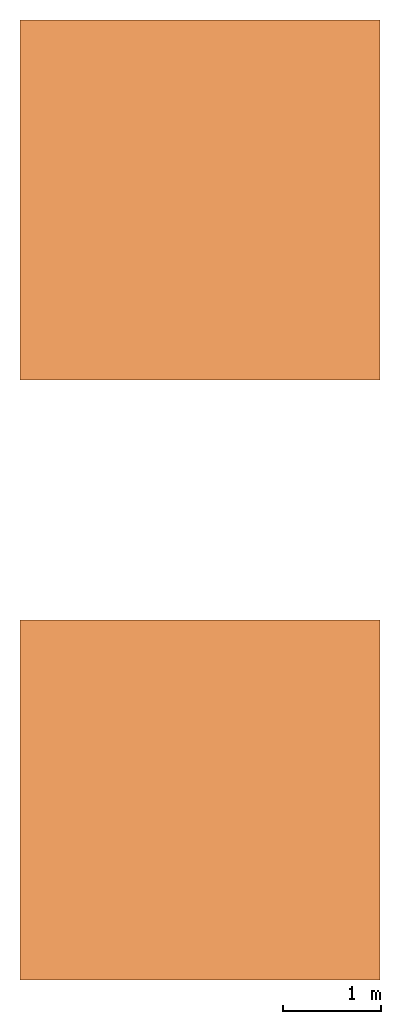
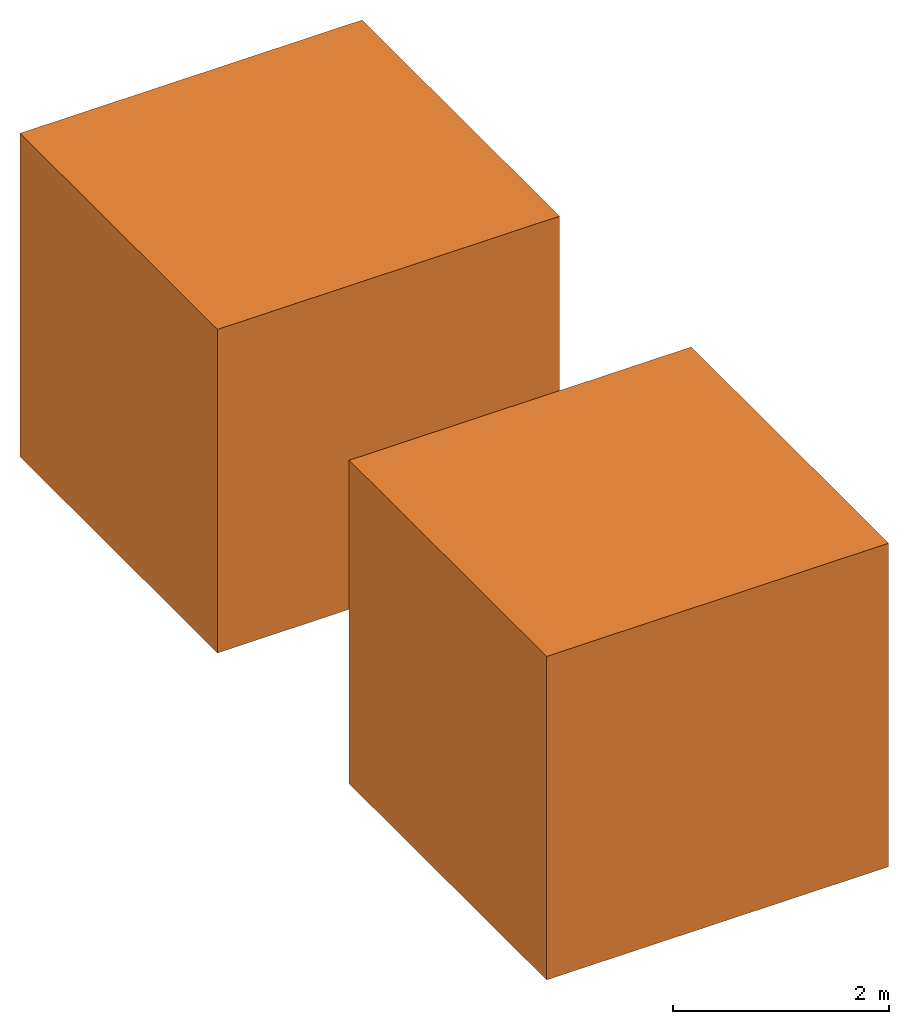
# One storey: 2 proxies.
"""IFC2X3 building model written with IfcOpenShell, lengths in feet."""

from ifc_helpers import new_model, entity, si_unit, converted_unit, frame, frame_2d, origin_with_axes, place, context, subcontext, project, spatial, faceted_brep, source, transform, mapped, material, type_object, type_shapes, element, save


model = new_model("IFC2X3")

# Units and contexts
model_context = context("Model", 3, precision=1e-05, world=origin_with_axes())
plan_context = context("Plan", 2, precision=1e-05, world=frame_2d((0.0, 0.0, 0.0), x_axis=(1.0, 0.0, 0.0)))
body_context = subcontext(model_context, "Body", "Model", "MODEL_VIEW")
ifc_project = project(units=[converted_unit("VOLUMEUNIT", "cubic foot", entity("IfcReal", 0.0283168467116885), si_unit("VOLUMEUNIT", "CUBIC_METRE"), dimensions=[3, 0, 0, 0, 0, 0, 0]), converted_unit("LENGTHUNIT", "foot", entity("IfcReal", 0.3048), si_unit("LENGTHUNIT", "METRE"), dimensions=[1, 0, 0, 0, 0, 0, 0]), converted_unit("AREAUNIT", "square foot", entity("IfcReal", 0.09290304), si_unit("AREAUNIT", "SQUARE_METRE"), dimensions=[2, 0, 0, 0, 0, 0, 0])], contexts=[model_context, plan_context])

# Site, building, storey
site_placement = place(None, origin_with_axes())
site = spatial("IfcSite", under=ifc_project, at=site_placement, CompositionType="ELEMENT")
building_placement = place(site_placement, origin_with_axes())
building = spatial("IfcBuilding", under=site, at=building_placement, Name="Building", CompositionType="ELEMENT")
storey_placement = place(building_placement, origin_with_axes())
storey = spatial("IfcBuildingStorey", under=building, at=storey_placement, Name="Storey", CompositionType="ELEMENT")

# Proxies
ifc_material = material(Name="Material")
building_element_proxy_type = type_object("IfcBuildingElementProxyType", Name="Cube", PredefinedType="NOTDEFINED", material=ifc_material)
shared_shape = source(origin_with_axes(), body_context, "Body", "Brep", [
    faceted_brep([(-12.0000009536743, 0.0, 0.0), (-12.0000009536743, 0.0, 12.0000009536743), (-12.0000009536743, 12.0, 12.0000009536743), (-12.0000009536743, 12.0, 0.0), (0.0, 12.0, 12.0000009536743), (0.0, 12.0, 0.0), (0.0, 0.0, 12.0000009536743), (0.0, 0.0, 0.0)], [[[0, 1, 2, 3]], [[3, 2, 4, 5]], [[5, 4, 6, 7]], [[7, 6, 1, 0]], [[3, 5, 7, 0]], [[4, 2, 1, 6]]]),
])
type_shapes(building_element_proxy_type, [shared_shape])
for number, where, z_axis, x_axis in (
    (1, (2.73774615110062e-06, 19.9999990738596, 0.0), (0.0, 0.0, 1.0), (1.0, 0.0, 0.0)),
    (2, (2.73774615110062e-06, 39.9999981477192, 0.0), (0.0, 0.0, 1.0), (1.0, 0.0, 0.0)),
):
    element("IfcBuildingElementProxy", number, at=place(storey_placement, frame(where, z_axis=z_axis, x_axis=x_axis)), inside=storey, type_object=building_element_proxy_type, context=body_context, shape_type="MappedRepresentation", body=[
        mapped(shared_shape, transform((0.0, 0.0, 0.0), x_axis=(1.0, 0.0, 0.0), y_axis=(0.0, 1.0, 0.0), z_axis=(0.0, 0.0, 1.0), scale=1.0)),
    ])

save(model, "model.ifc")
